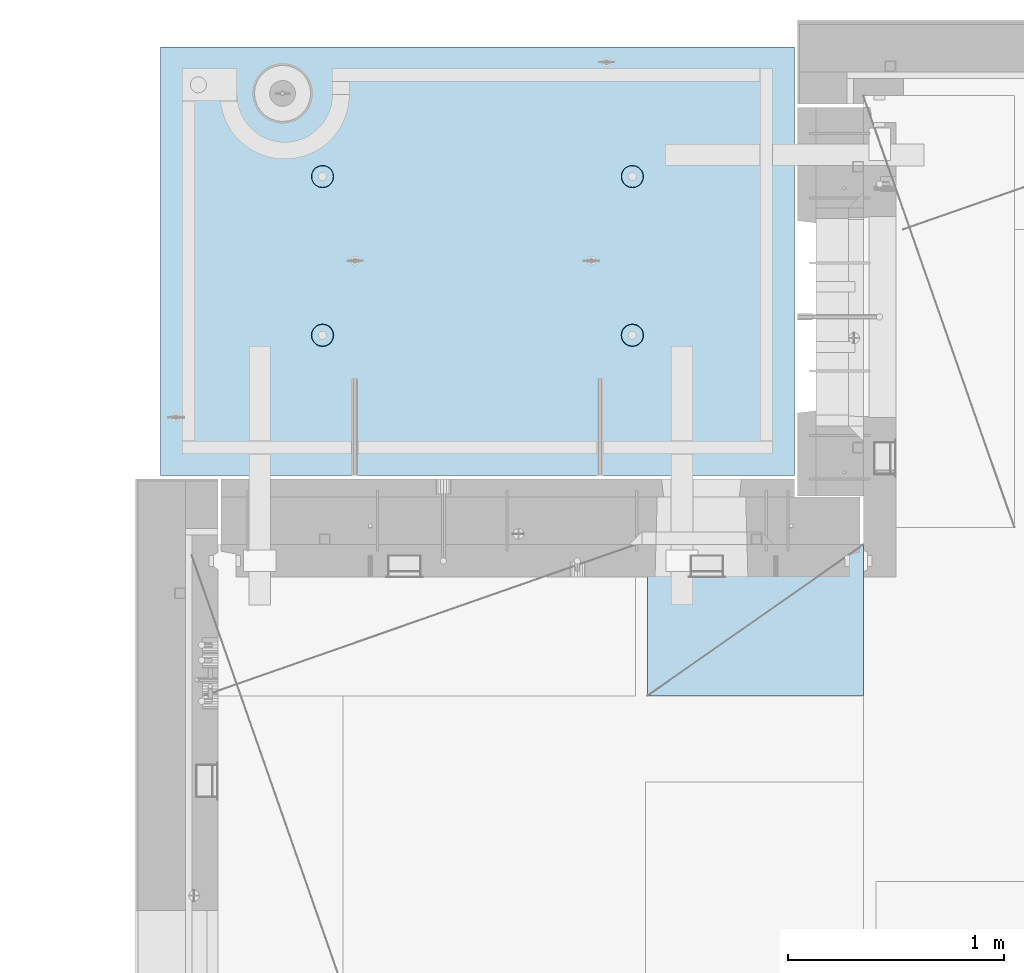
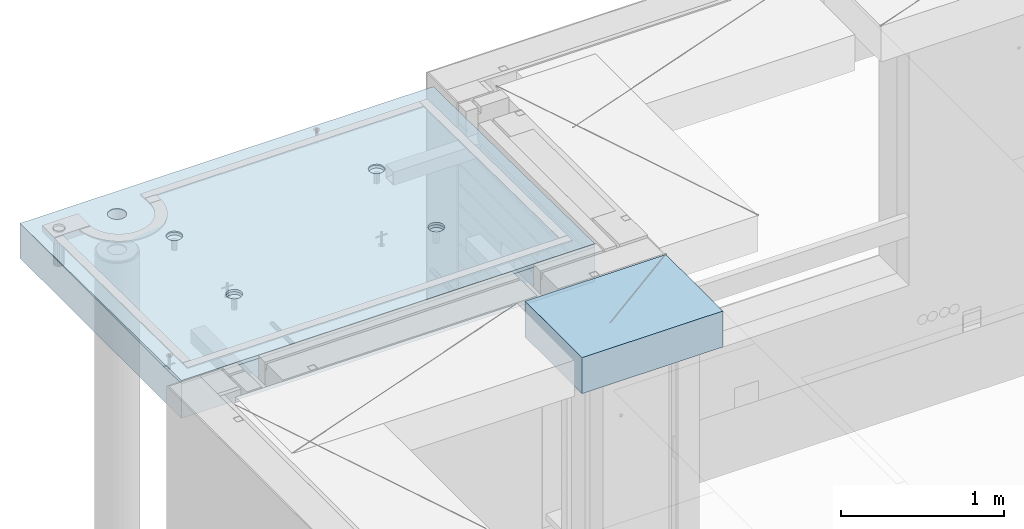
# One storey, part 206 of 350: 2 slabs, 1 plate, 2 elements without a shape of their own.
"""IFC2X3 building model written with IfcOpenShell, lengths in millimetres."""

import ifcopenshell
import ifcopenshell.guid

model = None  # the IFC model being written
_history = None  # IfcOwnerHistory: only IFC2X3 demands one
_inside = {}  # id of a spatial element -> (the spatial element, [elements in it])
_under = {}  # id of a project, library or spatial element -> (it, [spatial elements below it])
_declared = {}  # id of a project -> (the project, [libraries it declares])
_typed = {}  # id of a type object -> (the type object, [elements of that type])
_made_of = {}  # id of a material, layer set ... -> (it, [elements and type objects made of it])


def new_model(schema):
    """Start an empty IFC model of exactly this schema.

    Asked for "IFC4X3", IfcOpenShell would pick the latest addendum, in which some entities
    have other attributes; the version numbers below select the first issue.
    IFC2X3 requires an IfcOwnerHistory on every rooted entity: one is made here for all.
    """
    global model, _history
    if schema == "IFC4X3":
        model = ifcopenshell.file(schema_version=(4, 3, 0, 0))
    else:
        model = ifcopenshell.file(schema=schema)
    _inside.clear()
    _under.clear()
    _declared.clear()
    _typed.clear()
    _made_of.clear()
    _history = None
    if model.schema == "IFC2X3":
        org = make("IfcOrganization", Name="unknown")
        user = make(
            "IfcPersonAndOrganization",
            ThePerson=make("IfcPerson", FamilyName="unknown"),
            TheOrganization=org,
        )
        app = make(
            "IfcApplication",
            ApplicationDeveloper=org,
            Version="unknown",
            ApplicationFullName="unknown",
            ApplicationIdentifier="unknown",
        )
        _history = make(
            "IfcOwnerHistory",
            OwningUser=user,
            OwningApplication=app,
            ChangeAction="ADDED",
            CreationDate=0,
        )
    return model


def make(cls, **values):
    """One entity of the class cls with the attributes given. An attribute that is None is left unset."""
    return model.create_entity(
        cls, **{name: value for name, value in values.items() if value is not None}
    )


def rooted(cls, **values):
    """An entity with a GlobalId (a new one), such as an element, a storey or a relation."""
    return make(cls, GlobalId=ifcopenshell.guid.new(), OwnerHistory=_history, **values)


def si_unit(unit_type, name, prefix=None):
    """IfcSIUnit, for example si_unit("LENGTHUNIT", "METRE", prefix="MILLI")."""
    return make("IfcSIUnit", UnitType=unit_type, Prefix=prefix, Name=name)


def assignment(units):
    """IfcUnitAssignment: the units of a project."""
    return None if units is None else make("IfcUnitAssignment", Units=units)


def point(xyz):
    """IfcCartesianPoint."""
    return None if xyz is None else make("IfcCartesianPoint", Coordinates=xyz)


def direction(xyz):
    """IfcDirection."""
    return None if xyz is None else make("IfcDirection", DirectionRatios=xyz)


def frame(location, z_axis=None, x_axis=None):
    """IfcAxis2Placement3D, a coordinate frame: its origin and axes. An axis left out is left unset."""
    return make(
        "IfcAxis2Placement3D",
        Location=point(location),
        Axis=direction(z_axis),
        RefDirection=direction(x_axis),
    )


def origin_with_axes():
    """The frame at (0, 0, 0) with the z axis (0, 0, 1) and the x axis (1, 0, 0) written out."""
    return frame((0.0, 0.0, 0.0), z_axis=(0.0, 0.0, 1.0), x_axis=(1.0, 0.0, 0.0))


def place(relative_to, where):
    """IfcLocalPlacement: puts the frame where relative to a parent placement (None: the world)."""
    return make(
        "IfcLocalPlacement", PlacementRelTo=relative_to, RelativePlacement=where
    )


def context(
    kind, dimensions, precision=None, world=None, true_north=None, identifier=None
):
    """IfcGeometricRepresentationContext, for example the 3D "Model" context."""
    return make(
        "IfcGeometricRepresentationContext",
        ContextIdentifier=identifier,
        ContextType=kind,
        CoordinateSpaceDimension=dimensions,
        Precision=precision,
        WorldCoordinateSystem=world,
        TrueNorth=true_north,
    )


def subcontext(parent, identifier, kind, view, scale=None):
    """IfcGeometricRepresentationSubContext, for example "Body" below "Model"."""
    return make(
        "IfcGeometricRepresentationSubContext",
        ContextIdentifier=identifier,
        ContextType=kind,
        ParentContext=parent,
        TargetScale=scale,
        TargetView=view,
    )


def project(units=None, contexts=None):
    """IfcProject with its units and contexts."""
    return rooted(
        "IfcProject",
        Name="project",
        RepresentationContexts=contexts,
        UnitsInContext=assignment(units),
    )


def spatial(cls, under=None, at=None, **own):
    """A site, building, storey or space (cls), placed at a placement, below another one or the project."""
    s = rooted(cls, ObjectPlacement=at, **own)
    if under is not None:
        _under.setdefault(under.id(), (under, []))[1].append(s)
    return s


def faces_of(points, faces, orient=None, outer=None):
    """IfcFace entities. A face is a list of loops; a loop is a list of indices into points, from 0.

    orient and outer hold one flag for each loop. By default every Orientation is true, the
    first loop of a face is its IfcFaceOuterBound and the others are IfcFaceBound.
    """
    made = []
    for i, loops in enumerate(faces):
        bounds = []
        for j, loop in enumerate(loops):
            is_outer = j == 0 if outer is None else outer[i][j]
            bounds.append(
                make(
                    "IfcFaceOuterBound" if is_outer else "IfcFaceBound",
                    Bound=make("IfcPolyLoop", Polygon=[points[k] for k in loop]),
                    Orientation=True if orient is None else orient[i][j],
                )
            )
        made.append(make("IfcFace", Bounds=bounds))
    return made


def faceted_brep(points, faces, orient=None, outer=None, voids=None):
    """IfcFacetedBrep: a solid bounded by flat faces; with voids (closed shells), ...WithVoids."""
    shared = [point(p) for p in points]
    hull = make("IfcClosedShell", CfsFaces=faces_of(shared, faces, orient, outer))
    if voids is None:
        return make("IfcFacetedBrep", Outer=hull)
    return make(
        "IfcFacetedBrepWithVoids",
        Outer=hull,
        Voids=[
            make(cls, CfsFaces=faces_of(shared, fs, o, b)) for cls, fs, o, b in voids
        ],
    )


def shape(context_of_items, identifier, shape_type, items):
    """IfcShapeRepresentation: the items that make up one representation, for example the "Body"."""
    return make(
        "IfcShapeRepresentation",
        ContextOfItems=context_of_items,
        RepresentationIdentifier=identifier,
        RepresentationType=shape_type,
        Items=items,
    )


def material(Name=None, Category=None):
    """IfcMaterial."""
    return make("IfcMaterial", Name=Name, Category=Category)


def made_of(thing, what):
    """Note that an element or type object is made of a material, layer set ...; save() writes the relation."""
    if what is not None:
        _made_of.setdefault(what.id(), (what, []))[1].append(thing)
    return thing


def type_object(cls, material=None, **own):
    """A type object (cls), such as IfcWallType, which elements share."""
    return made_of(rooted(cls, **own), material)


def element(
    cls,
    number,
    at=None,
    inside=None,
    cuts=None,
    type_object=None,
    material=None,
    context=None,
    identifier="Body",
    shape_type=None,
    held_by="IfcProductDefinitionShape",
    body=None,
    shapes=None,
    **own,
):
    """One element of the class cls, such as IfcWall. Its Tag is "e" and its number.

    at: its placement. inside: the storey or other place that contains it. cuts: it is an
    opening in that element (IfcRelVoidsElement). A single representation is given by context,
    identifier, shape_type and body (its items); several are given by shapes. held_by: the class
    of the entity that holds the representations. save() writes the other relations.
    """
    e = rooted(cls, Tag="e%d" % number, ObjectPlacement=at, **own)
    if body is not None:
        shapes = [shape(context, identifier, shape_type, body)]
    if shapes is not None:
        e.Representation = make(held_by, Representations=shapes)
    if inside is not None:
        _inside.setdefault(inside.id(), (inside, []))[1].append(e)
    if cuts is not None:
        rooted(
            "IfcRelVoidsElement", RelatingBuildingElement=cuts, RelatedOpeningElement=e
        )
    if type_object is not None:
        _typed.setdefault(type_object.id(), (type_object, []))[1].append(e)
    return made_of(e, material)


def aggregate(whole, parts):
    """IfcRelAggregates: a whole, such as a stair, and the parts it consists of."""
    return rooted("IfcRelAggregates", RelatingObject=whole, RelatedObjects=parts)


def save(model, path):
    """Write the relations noted so far, then the file.

    IfcRelAggregates (storeys below a building ...), IfcRelContainedInSpatialStructure (elements
    in a storey), IfcRelDefinesByType, IfcRelAssociatesMaterial and IfcRelDeclares: one each for
    every whole, place, type object, material and project.
    """
    for whole, parts in _under.values():
        aggregate(whole, parts)
    for where, things in _inside.values():
        rooted(
            "IfcRelContainedInSpatialStructure",
            RelatedElements=things,
            RelatingStructure=where,
        )
    for kind, things in _typed.values():
        rooted("IfcRelDefinesByType", RelatedObjects=things, RelatingType=kind)
    for what, things in _made_of.values():
        rooted("IfcRelAssociatesMaterial", RelatedObjects=things, RelatingMaterial=what)
    for by, libraries in _declared.values():
        rooted("IfcRelDeclares", RelatingContext=by, RelatedDefinitions=libraries)
    model.write(path)


model = new_model("IFC2X3")

# Units and contexts
model_context = context("Model", 3, precision=1e-05, world=origin_with_axes())
body_context = subcontext(model_context, "Body", "Model", "MODEL_VIEW")
ifc_project = project(units=[si_unit("LENGTHUNIT", "METRE", prefix="MILLI"), si_unit("AREAUNIT", "SQUARE_METRE"), si_unit("VOLUMEUNIT", "CUBIC_METRE"), si_unit("MASSUNIT", "GRAM", prefix="KILO"), si_unit("TIMEUNIT", "SECOND"), si_unit("PLANEANGLEUNIT", "RADIAN"), si_unit("SOLIDANGLEUNIT", "STERADIAN"), si_unit("THERMODYNAMICTEMPERATUREUNIT", "DEGREE_CELSIUS"), si_unit("LUMINOUSINTENSITYUNIT", "LUMEN")], contexts=[model_context])

# Site, building, storey
site_placement = place(None, origin_with_axes())
site = spatial("IfcSite", under=ifc_project, at=site_placement, CompositionType="ELEMENT")
building_placement = place(site_placement, origin_with_axes())
building = spatial("IfcBuilding", under=site, at=building_placement, CompositionType="ELEMENT")
storey_placement = place(building_placement, origin_with_axes())
storey = spatial("IfcBuildingStorey", under=building, at=storey_placement, Name="2", CompositionType="ELEMENT", Elevation=0.0)

# Assembly, slabs
assembly_1_placement = place(storey_placement, origin_with_axes())
assembly_1 = element("IfcElementAssembly", 1, at=assembly_1_placement, inside=storey, AssemblyPlace="NOTDEFINED", PredefinedType="REINFORCEMENT_UNIT")
ifc_material_1 = material(Name="CONCRETE/C35/45")
slab_type_1 = type_object("IfcSlabType", PredefinedType="NOTDEFINED")
slab_1_placement = place(assembly_1_placement, frame((7734.99985681325, 20899.9965573523, 87717.5), z_axis=(0.0, 1.0, 0.0), x_axis=(1.0, 0.0, 0.0)))
slab_1 = element("IfcSlab", 2, at=slab_1_placement, type_object=slab_type_1, material=ifc_material_1, PredefinedType="FLOOR", context=body_context, shape_type="Brep", body=[
    faceted_brep([(209.64691778923, 8.87688398158934, 1795.66138892724), (209.64691778923, 12.5000000975269, 1795.66138892724), (201.519156607756, 12.5000000956934, 1783.49470026561), (201.519156607756, 8.73204270274437, 1783.49470026561), (189.354094229504, 12.5000000940054, 1775.36450517907), (189.354094229504, 8.63525483493868, 1775.36450517907), (175.003751124998, 12.5000000927103, 1772.50855216914), (175.003751124998, 8.60125545370101, 1772.50855216914), (160.652836945715, 12.5000000920118, 1775.36163419229), (160.652836945715, 8.63522065659345, 1775.36163419229), (148.48614828409, 12.5000000919972, 1783.48939537376), (148.48614828409, 8.73197954936768, 1783.48939537376), (140.355953197546, 12.5000000926811, 1795.65445775201), (140.355953197546, 8.87680146773346, 1795.65445775201), (137.500000187611, 12.5000000939617, 1810.00480085652), (137.500000187611, 9.04763858744991, 1810.00480085652), (140.353082210766, 12.5000000956497, 1824.35571503581), (140.353082210766, 9.21848250564653, 1824.35571503581), (148.48084339224, 12.5000000974687, 1836.52240369743), (148.48084339224, 9.36332378449151, 1836.52240369743), (160.645905770492, 12.5000000991568, 1844.65259878397), (160.645905770492, 9.4601116522972, 1844.65259878397), (174.996248874998, 12.5000001004519, 1847.50855179391), (174.996248874998, 9.49411103353486, 1847.50855179391), (189.347163054282, 12.5000001011649, 1844.65546977075), (189.347163054282, 9.46014583064243, 1844.65546977075), (201.513851715907, 12.5000001011795, 1836.52770858928), (201.513851715907, 9.3633869378682, 1836.52770858928), (209.64404680245, 12.500000100481, 1824.36264621103), (209.64404680245, 9.21856501948787, 1824.36264621103), (212.499999812386, 12.5000000992004, 1810.01230310652), (212.499999812386, 9.04772789980052, 1810.01230310652), (0.0, 12.5, 1985.00366210938), (7.41420080885291e-08, 12.4999999999927, 0.0), (-7.41420080885291e-08, -12.5, -3.63797880709171e-12), (0.0, 11.1309547276614, 1985.00366210938), (2935.0, 12.5000004097383, 1985.00366209901), (2935.0, 11.1309547276614, 1985.00366210938), (2935.0, 12.5, 0.0), (2935.0, -12.5, 0.0), (2234.65136896188, -4.56985165992228, 666.133623356985), (2233.6850359994, 12.5000001221924, 665.819642744358), (2236.1904762364, 12.5000001207372, 650.000915653603), (2237.21797072983, -4.76190736876742, 650.000915653603), (2227.22763735012, -4.39666783543362, 680.68109000706), (2226.41396523543, 12.5000001231529, 680.089922611885), (2215.67536748502, -4.25927704213245, 692.221936790684), (2215.08900701139, 12.5000001235312, 691.414880835895), (2201.12537297611, -4.17108941465267, 699.629710429519), (2200.81872714385, 12.5000001232838, 698.685951599829), (2185.00000005312, -4.14070613867079, 702.181910066618), (2185.00000005312, 12.5000001224398, 701.19139183679), (2168.87462713012, -4.17108941465267, 699.629710429519), (2169.18127296234, 12.5000001210865, 698.685951599953), (2154.32463262121, -4.25927704213245, 692.221936790684), (2154.9109930947, 12.5000001193257, 691.414880836099), (2142.77236275611, -4.39666783543362, 680.68109000706), (2143.58603487053, 12.5000001173757, 680.089922612086), (2135.34863114435, -4.56985165992228, 666.133623356985), (2136.31496410644, 12.5000001153967, 665.819642744485), (2132.7820293764, -4.76190736876742, 650.000915653603), (2133.8095238694, 12.5000001135923, 650.000915653603), (2135.3268816397, -4.95404720651277, 633.861141107776), (2136.31496410626, 12.5000001121371, 634.182188562663), (2142.73717131393, -5.12745128343522, 619.29517322078), (2143.58603487023, 12.5000001111621, 619.911908694903), (2154.28944117357, -5.26511432380357, 607.731457644233), (2154.9109930944, 12.5000001107837, 608.586950470697), (2168.85287761663, -5.35352220384812, 600.305182758089), (2169.18127296215, 12.5000001110311, 601.315879706683), (2185.00000005312, -5.38398960883205, 597.745916272124), (2185.00000005312, 12.5000001118751, 598.810439469788), (2201.1471224896, -5.35352220384812, 600.305182758089), (2200.81872714404, 12.500000113243, 601.31587970681), (2215.71055893266, -5.26511432380357, 607.731457644233), (2215.08900701168, 12.5000001149892, 608.586950470901), (2227.2628287923, -5.12745128343522, 619.29517322078), (2226.41396523573, 12.5000001169392, 619.911908695103), (2234.67311846653, -4.95404720651277, 633.861141107776), (2233.68503599959, 12.5000001189328, 634.182188562787), (799.651368961879, -4.56985165992228, 666.133623356985), (798.685036005074, 12.5000000220316, 665.819642746203), (801.190476242367, 12.5000000205619, 650.000915653603), (802.217970729829, -4.76190736876742, 650.000915653603), (792.227637350119, -4.39666783543362, 680.68109000706), (791.41396524025, 12.500000022992, 680.089922615389), (780.675367485019, -4.25927704213245, 692.221936790684), (780.089007014889, 12.5000000233704, 691.414880840719), (766.125372976112, -4.17108941465267, 699.629710429519), (765.818727145695, 12.500000023123, 698.685951605497), (750.000000053116, -4.14070613867079, 702.181910066618), (750.000000053116, 12.500000022279, 701.191391842753), (733.874627130121, -4.17108941465267, 699.629710429519), (734.181272960497, 12.5000000209257, 698.685951605625), (719.324632621214, -4.25927704213245, 692.221936790684), (719.910993091196, 12.5000000191649, 691.414880840923), (707.772362756114, -4.39666783543362, 680.68109000706), (708.586034865702, 12.5000000172149, 680.089922615593), (700.348631144354, -4.56985165992228, 666.133623356985), (701.314964100775, 12.5000000152359, 665.819642746326), (697.782029376403, -4.76190736876742, 650.000915653603), (698.80952386344, 12.5000000134314, 650.000915653603), (700.326881639705, -4.95404720651277, 633.861141107776), (701.314964100589, 12.5000000119617, 634.182188560822), (707.737171313933, -5.12745128343522, 619.29517322078), (708.586034865404, 12.5000000110012, 619.911908691396), (719.289441173572, -5.26511432380357, 607.731457644233), (719.910993090896, 12.5000000106229, 608.586950465873), (733.852877616633, -5.35352220384812, 600.305182758089), (734.181272960313, 12.5000000108703, 601.315879701015), (750.000000053116, -5.38398960883205, 597.745916272124), (750.000000053116, 12.5000000117143, 598.810439463825), (766.1471224896, -5.35352220384812, 600.305182758089), (765.818727145879, 12.5000000130822, 601.315879701138), (780.71055893266, -5.26511432380357, 607.731457644233), (780.089007015189, 12.5000000148284, 608.586950466077), (792.2628287923, -5.12745128343522, 619.29517322078), (791.413965240548, 12.5000000167784, 619.9119086916), (799.673118466528, -4.95404720651277, 633.861141107776), (798.685036005258, 12.500000018772, 634.182188560946), (799.156135017123, 4.17823925742414, 1400.9745431382), (798.685035917459, 12.5000000978907, 1400.82147376184), (801.190476154532, 12.5000000964355, 1385.00274667064), (801.697136924844, 3.98809915517631, 1385.00274667064), (791.806449365287, 4.3496957076859, 1415.37691010137), (791.413965153277, 12.5000000988512, 1415.09175362977), (780.369404424282, 4.48571613449894, 1426.80264589727), (780.089006928914, 12.5000000992295, 1426.4167118541), (765.96453481571, 4.57302415884624, 1434.13653274457), (765.818727060978, 12.5000000989821, 1433.68778261824), (749.999999969796, 4.6031043852272, 1436.66327617152), (749.999999969796, 12.5000000981381, 1436.19322285528), (734.035465123881, 4.57302415884624, 1434.13653274457), (734.181272878572, 12.5000000967848, 1433.68778261837), (719.630595515309, 4.48571613449894, 1426.80264589727), (719.91099301053, 12.5000000950386, 1426.41671185431), (708.193550574304, 4.3496957076859, 1415.37691010137), (708.586034786036, 12.5000000930741, 1415.09175362997), (700.843864922468, 4.17823925742414, 1400.9745431382), (701.314964021747, 12.500000091095, 1400.82147376197), (698.302863014747, 3.98809915517631, 1385.00274667064), (698.809523784634, 12.500000089276, 1385.00274667064), (700.822332352242, 3.79787576314993, 1369.0239538469), (701.314964021563, 12.5000000878208, 1369.18401957925), (708.15871013944, 3.62620125728427, 1354.60327018229), (708.586034785736, 12.5000000868604, 1354.91373971109), (719.595755075041, 3.48991129887872, 1343.15489369192), (719.91099301023, 12.500000086482, 1343.58878148656), (734.013932544907, 3.40238521881111, 1335.80269013289), (734.181272878388, 12.5000000867294, 1336.31771072235), (749.999999969796, 3.37222170254972, 1333.26895034341), (749.999999969796, 12.5000000875589, 1333.81227048538), (765.986067394684, 3.40238521881111, 1335.80269013289), (765.818727061163, 12.5000000889413, 1336.31771072247), (780.40424486455, 3.48991129887872, 1343.15489369192), (780.089006929215, 12.500000090673, 1343.58878148677), (791.841289800152, 3.62620125728427, 1354.60327018229), (791.413965153577, 12.5000000926375, 1354.91373971129), (799.17766758735, 3.79787576314993, 1369.0239538469), (798.685035917644, 12.5000000946166, 1369.18401957938), (2234.15613501712, 4.17823925742414, 1400.9745431382), (2233.68503591179, 12.5000001980516, 1400.82147376), (2236.19047614857, 12.5000001965964, 1385.00274667064), (2236.69713692484, 3.98809915517631, 1385.00274667064), (2226.80644936529, 4.3496957076859, 1415.37691010137), (2226.41396514845, 12.5000001990265, 1415.09175362627), (2215.36940442428, 4.48571613449894, 1426.80264589727), (2215.08900692541, 12.5000001993903, 1426.41671184928), (2200.96453481571, 4.57302415884624, 1434.13653274457), (2200.81872705914, 12.5000001991575, 1433.68778261257), (2184.9999999698, 4.6031043852272, 1436.66327617152), (2184.9999999698, 12.5000001982989, 1436.19322284931), (2169.03546512388, 4.57302415884624, 1434.13653274457), (2169.18127288041, 12.5000001969456, 1433.6877826127), (2154.63059551531, 4.48571613449894, 1426.80264589727), (2154.91099301403, 12.5000001951994, 1426.41671184948), (2143.1935505743, 4.3496957076859, 1415.37691010137), (2143.58603479086, 12.5000001932349, 1415.09175362647), (2135.84386492247, 4.17823925742414, 1400.9745431382), (2136.31496402742, 12.5000001912558, 1400.82147376013), (2133.30286301475, 3.98809915517631, 1385.00274667064), (2133.8095237906, 12.5000001894368, 1385.00274667064), (2135.82233235224, 3.79787576314993, 1369.0239538469), (2136.31496402723, 12.5000001879816, 1369.18401958109), (2143.15871013944, 3.62620125728427, 1354.60327018229), (2143.58603479056, 12.5000001870212, 1354.91373971459), (2154.59575507504, 3.48991129887872, 1343.15489369192), (2154.91099301373, 12.5000001866429, 1343.58878149139), (2169.01393254491, 3.40238521881111, 1335.80269013289), (2169.18127288023, 12.5000001868902, 1336.31771072802), (2184.9999999698, 3.37222170254972, 1333.26895034341), (2184.9999999698, 12.5000001877343, 1333.81227049134), (2200.98606739468, 3.40238521881111, 1335.80269013289), (2200.81872705932, 12.5000001891021, 1336.31771072814), (2215.40424486455, 3.48991129887872, 1343.15489369192), (2215.08900692571, 12.5000001908338, 1343.58878149159), (2226.84128980015, 3.62620125728427, 1354.60327018229), (2226.41396514875, 12.5000001927983, 1354.9137397148), (2234.17766758735, 3.79787576314993, 1369.0239538469), (2233.68503591197, 12.5000001947919, 1369.18401958122), (613.539958053605, 8.15176414522284, 1734.75121634823), (600.266053528658, 7.99374174815603, 1721.47731182328), (583.539958053605, 7.89228512388945, 1712.95494050807), (564.998938391109, 7.85732555369032, 1710.01833148578), (546.457918728613, 7.89228512388945, 1712.95494050807), (529.73182325356, 7.99374174815603, 1721.47731182328), (516.457918728613, 8.15176414522284, 1734.75121634823), (507.935547413399, 8.35088398186781, 1751.47731182328), (504.998938391109, 8.57161002114299, 1770.01833148578), (507.935547413399, 8.79233606038906, 1788.55935114828), (516.457918728613, 8.99145589703403, 1805.28544662333), (529.73182325356, 9.1494782941154, 1818.55935114828), (546.457918728613, 9.25093491838197, 1827.08172246349), (564.998938391109, 9.28589448856656, 1830.01833148578), (583.539958053605, 9.25093491838197, 1827.08172246349), (600.266053528658, 9.1494782941154, 1818.55935114828), (613.539958053605, 8.99145589703403, 1805.28544662333), (622.062329368819, 8.79233606038906, 1788.55935114828), (624.998938391109, 8.57161002114299, 1770.01833148578), (622.062329368819, 8.35088398186781, 1751.47731182328), (613.539958053605, 12.5, 1805.28544662333), (622.062329368819, 12.5, 1788.55935114828), (600.266053528658, 12.5, 1818.55935114828), (583.539958053605, 12.5, 1827.08172246349), (564.998938391109, 12.5, 1830.01833148578), (546.457918728613, 12.5, 1827.08172246349), (529.73182325356, 12.5, 1818.55935114828), (516.457918728613, 12.5, 1805.28544662333), (507.935547413399, 12.5, 1788.55935114828), (504.998938391109, 12.5, 1770.01833148578), (507.935547413399, 12.5, 1751.47731182328), (516.457918728613, 12.5, 1734.75121634823), (529.73182325356, 12.5, 1721.47731182328), (546.457918728613, 12.5, 1712.95494050807), (564.998938391109, 12.5, 1710.01833148578), (583.539958053605, 12.5, 1712.95494050807), (600.266053528658, 12.5, 1721.47731182328), (613.539958053605, 12.5, 1734.75121634823), (622.062329368819, 12.5, 1751.47731182328), (624.998938391109, 12.5, 1770.01833148578)], [[[0, 1, 2, 3]], [[3, 2, 4, 5]], [[5, 4, 6, 7]], [[7, 6, 8, 9]], [[9, 8, 10, 11]], [[11, 10, 12, 13]], [[13, 12, 14, 15]], [[15, 14, 16, 17]], [[17, 16, 18, 19]], [[19, 18, 20, 21]], [[21, 20, 22, 23]], [[23, 22, 24, 25]], [[25, 24, 26, 27]], [[27, 26, 28, 29]], [[29, 28, 30, 31]], [[31, 30, 1, 0]], [[32, 33, 34, 35]], [[36, 32, 35, 37]], [[38, 36, 37, 39]], [[33, 38, 39, 34]], [[40, 41, 42, 43]], [[44, 45, 41, 40]], [[46, 47, 45, 44]], [[48, 49, 47, 46]], [[50, 51, 49, 48]], [[52, 53, 51, 50]], [[53, 52, 54, 55]], [[55, 54, 56, 57]], [[57, 56, 58, 59]], [[59, 58, 60, 61]], [[61, 60, 62, 63]], [[63, 62, 64, 65]], [[65, 64, 66, 67]], [[67, 66, 68, 69]], [[69, 68, 70, 71]], [[72, 73, 71, 70]], [[74, 75, 73, 72]], [[76, 77, 75, 74]], [[78, 79, 77, 76]], [[43, 42, 79, 78]], [[80, 81, 82, 83]], [[84, 85, 81, 80]], [[86, 87, 85, 84]], [[88, 89, 87, 86]], [[90, 91, 89, 88]], [[92, 93, 91, 90]], [[93, 92, 94, 95]], [[95, 94, 96, 97]], [[97, 96, 98, 99]], [[99, 98, 100, 101]], [[101, 100, 102, 103]], [[103, 102, 104, 105]], [[105, 104, 106, 107]], [[107, 106, 108, 109]], [[109, 108, 110, 111]], [[112, 113, 111, 110]], [[114, 115, 113, 112]], [[116, 117, 115, 114]], [[118, 119, 117, 116]], [[83, 82, 119, 118]], [[120, 121, 122, 123]], [[124, 125, 121, 120]], [[126, 127, 125, 124]], [[128, 129, 127, 126]], [[130, 131, 129, 128]], [[132, 133, 131, 130]], [[134, 135, 133, 132]], [[135, 134, 136, 137]], [[137, 136, 138, 139]], [[139, 138, 140, 141]], [[141, 140, 142, 143]], [[143, 142, 144, 145]], [[145, 144, 146, 147]], [[147, 146, 148, 149]], [[149, 148, 150, 151]], [[151, 150, 152, 153]], [[154, 155, 153, 152]], [[156, 157, 155, 154]], [[158, 159, 157, 156]], [[123, 122, 159, 158]], [[160, 161, 162, 163]], [[164, 165, 161, 160]], [[166, 167, 165, 164]], [[168, 169, 167, 166]], [[170, 171, 169, 168]], [[172, 173, 171, 170]], [[174, 175, 173, 172]], [[175, 174, 176, 177]], [[177, 176, 178, 179]], [[179, 178, 180, 181]], [[181, 180, 182, 183]], [[183, 182, 184, 185]], [[185, 184, 186, 187]], [[187, 186, 188, 189]], [[189, 188, 190, 191]], [[191, 190, 192, 193]], [[194, 195, 193, 192]], [[196, 197, 195, 194]], [[198, 199, 197, 196]], [[163, 162, 199, 198]], [[37, 35, 34, 39], [3, 5, 7, 9, 11, 13, 15, 17, 19, 21, 23, 25, 27, 29, 31, 0], [200, 201, 202, 203, 204, 205, 206, 207, 208, 209, 210, 211, 212, 213, 214, 215, 216, 217, 218, 219], [196, 194, 192, 190, 188, 186, 184, 182, 180, 178, 176, 174, 172, 170, 168, 166, 164, 160, 163, 198], [156, 154, 152, 150, 148, 146, 144, 142, 140, 138, 136, 134, 132, 130, 128, 126, 124, 120, 123, 158], [116, 114, 112, 110, 108, 106, 104, 102, 100, 98, 96, 94, 92, 90, 88, 86, 84, 80, 83, 118], [76, 74, 72, 70, 68, 66, 64, 62, 60, 58, 56, 54, 52, 50, 48, 46, 44, 40, 43, 78]], [[216, 220, 221, 217]], [[215, 222, 220, 216]], [[214, 223, 222, 215]], [[213, 224, 223, 214]], [[212, 225, 224, 213]], [[211, 226, 225, 212]], [[210, 227, 226, 211]], [[209, 228, 227, 210]], [[208, 229, 228, 209]], [[207, 230, 229, 208]], [[206, 231, 230, 207]], [[205, 232, 231, 206]], [[204, 233, 232, 205]], [[203, 234, 233, 204]], [[202, 235, 234, 203]], [[201, 236, 235, 202]], [[200, 237, 236, 201]], [[219, 238, 237, 200]], [[218, 239, 238, 219]], [[217, 221, 239, 218]], [[38, 33, 32, 36], [26, 24, 22, 20, 18, 16, 14, 12, 10, 8, 6, 4, 2, 1, 30, 28], [220, 222, 223, 224, 225, 226, 227, 228, 229, 230, 231, 232, 233, 234, 235, 236, 237, 238, 239, 221], [165, 167, 169, 171, 173, 175, 177, 179, 181, 183, 185, 187, 189, 191, 193, 195, 197, 199, 162, 161], [125, 127, 129, 131, 133, 135, 137, 139, 141, 143, 145, 147, 149, 151, 153, 155, 157, 159, 122, 121], [85, 87, 89, 91, 93, 95, 97, 99, 101, 103, 105, 107, 109, 111, 113, 115, 117, 119, 82, 81], [45, 47, 49, 51, 53, 55, 57, 59, 61, 63, 65, 67, 69, 71, 73, 75, 77, 79, 42, 41]]]),
])
slab_type_2 = type_object("IfcSlabType", PredefinedType="NOTDEFINED")
slab_2_placement = place(assembly_1_placement, frame((7734.99985681325, 20899.9965573523, 87575.0), z_axis=(-2.2639999995273e-06, 0.999999999997437, 0.0), x_axis=(0.999999999997251, 2.34499999952812e-06, 0.0)))
slab_2 = element("IfcSlab", 3, at=slab_2_placement, type_object=slab_type_2, material=ifc_material_1, PredefinedType="FLOOR", context=body_context, shape_type="Brep", body=[
    faceted_brep([(2200.45398600256, -110.0, 1337.44476079497), (2214.39241555253, -110.0, 1344.54670420538), (2225.45402859605, -110.0, 1355.60826537005), (2232.55603737762, -110.0, 1369.54666161175), (2235.0032477951, -110.0, 1384.99750559184), (2232.5561098421, -110.0, 1400.44836104917), (2225.45416643169, -110.0, 1414.38679059914), (2214.39260526702, -110.0, 1425.44840364265), (2200.45420902531, -110.0, 1432.55041242422), (2185.00336504523, -110.0, 1434.9976228417), (2169.55250958791, -110.0, 1432.55048488871), (2155.61408003793, -110.0, 1425.44854147829), (2144.55246699442, -110.0, 1414.38698031362), (2137.45045821285, -110.0, 1400.44858407192), (2135.00324779537, -110.0, 1384.99774009184), (2137.45038574836, -110.0, 1369.54688463451), (2144.55232915878, -110.0, 1355.60845508454), (2155.61389032345, -110.0, 1344.54684204102), (2169.55228656515, -110.0, 1337.44483325945), (2185.00313054523, -110.0, 1334.99762284198), (2226.41728354208, -130.0, 1415.08653268859), (2233.68832084322, -130.0, 1400.81623576839), (2215.09235187349, -130.0, 1426.41151747124), (2200.8220890546, -130.0, 1433.68262169999), (2185.0033678369, -130.0, 1436.18809903217), (2169.18463486868, -130.0, 1433.68269588982), (2154.91433794847, -130.0, 1426.41165858869), (2143.58935316583, -130.0, 1415.08672692009), (2136.31824893708, -130.0, 1400.81646410121), (2133.8127716049, -130.0, 1384.9977428835), (2136.31817474725, -130.0, 1369.17900991529), (2143.58921204838, -130.0, 1354.90871299508), (2154.91414371698, -130.0, 1343.58372821243), (2169.18440653586, -130.0, 1336.31262398369), (2185.00312775357, -130.0, 1333.8071466515), (2200.82186072178, -130.0, 1336.31254979386), (2215.09215764199, -130.0, 1343.58358709499), (2226.41714242464, -130.0, 1354.90851876358), (2233.68824665339, -130.0, 1369.17878158247), (2236.19372398557, -130.0, 1384.99750280017), (765.453986006505, -110.0, 1337.44812586997), (779.392415556478, -110.0, 1344.55006928038), (790.454028599992, -110.0, 1355.61163044505), (797.556037381562, -110.0, 1369.55002668675), (800.003247799041, -110.0, 1385.00087066684), (797.556109846048, -110.0, 1400.45172612417), (790.454166435635, -110.0, 1414.39015567414), (779.392605270965, -110.0, 1425.45176871765), (765.45420902926, -110.0, 1432.55377749922), (750.003365049179, -110.0, 1435.0009879167), (734.552509591851, -110.0, 1432.55384996371), (720.614080041878, -110.0, 1425.4519065533), (709.552466998364, -110.0, 1414.39034538862), (702.450458216794, -110.0, 1400.45194914692), (700.003247799315, -110.0, 1385.00110516684), (702.450385752309, -110.0, 1369.5502497095), (709.552329162721, -110.0, 1355.61182015954), (720.613890327391, -110.0, 1344.55020711602), (734.552286569096, -110.0, 1337.44819833446), (750.003130549179, -110.0, 1335.00098791698), (798.688320847163, -130.0, 1400.81960084339), (801.193723989514, -130.0, 1385.00086787517), (791.417283546027, -130.0, 1415.0898977636), (780.092351877434, -130.0, 1426.41488254624), (765.822089058547, -130.0, 1433.68598677499), (750.003367840845, -130.0, 1436.19146410717), (734.184634872629, -130.0, 1433.68606096482), (719.914337952418, -130.0, 1426.41502366369), (708.589353169771, -130.0, 1415.09009199509), (701.318248941023, -130.0, 1400.81982917621), (698.812771608842, -130.0, 1385.00110795851), (701.318174751194, -130.0, 1369.18237499029), (708.589212052329, -130.0, 1354.91207807008), (719.914143720922, -130.0, 1343.58709328743), (734.184406539811, -130.0, 1336.31598905868), (750.003127757513, -130.0, 1333.8105117265), (765.821860725729, -130.0, 1336.31591486885), (780.092157645939, -130.0, 1343.58695216999), (791.417142428585, -130.0, 1354.91188383858), (798.688246657333, -130.0, 1369.18214665747), (2935.0, -130.0, 1.16051523946226e-09), (0.0, -130.0, -3.63797880709171e-12), (0.0, 130.0, -1.81898940354586e-12), (2935.0, 130.0, 1.16051523946226e-09), (2935.00146484375, -130.0, 1985.00366210938), (2935.00146484375, 130.0, 1985.00366210938), (0.00127768016045593, -130.0, 1985.00366210937), (0.00127768016045593, 130.0, 1985.00366210937), (613.544191446293, 130.0, 1805.28400786653), (600.270318048689, 130.0, 1818.55794351875), (583.544242558642, 130.0, 1827.08035405663), (565.003229782545, 130.0, 1830.0170065576), (546.462203233751, 130.0, 1827.08044101401), (529.736087773786, 130.0, 1818.55810892152), (516.462152121568, 130.0, 1805.28423552391), (507.939741583684, 130.0, 1788.55816003387), (505.00308908271, 130.0, 1770.01714725777), (507.939654626302, 130.0, 1751.47612070897), (516.461986718798, 130.0, 1734.75000524901), (529.735860116402, 130.0, 1721.47606959679), (546.461935606448, 130.0, 1712.95365905891), (565.002948382545, 130.0, 1710.01700655793), (583.543974931338, 130.0, 1712.95357210152), (600.270090391306, 130.0, 1721.47590419402), (613.544026043523, 130.0, 1734.74977759163), (622.066436581407, 130.0, 1751.47585308167), (625.003089082381, 130.0, 1770.01686585777), (622.066523538789, 130.0, 1788.55789240656), (622.066523538789, -130.0, 1788.55789240656), (625.003089082381, -130.0, 1770.01686585777), (613.544191446293, -130.0, 1805.28400786653), (600.270318048689, -130.0, 1818.55794351875), (583.544242558642, -130.0, 1827.08035405663), (565.003229782545, -130.0, 1830.0170065576), (546.462203233751, -130.0, 1827.08044101401), (529.736087773786, -130.0, 1818.55810892152), (516.462152121568, -130.0, 1805.28423552391), (507.939741583684, -130.0, 1788.55816003387), (505.00308908271, -130.0, 1770.01714725777), (507.939654626302, -130.0, 1751.47612070897), (516.461986718798, -130.0, 1734.75000524901), (529.735860116402, -130.0, 1721.47606959679), (546.461935606448, -130.0, 1712.95365905891), (565.002948382545, -130.0, 1710.01700655793), (583.543974931338, -130.0, 1712.95357210152), (600.270090391306, -130.0, 1721.47590419402), (613.544026043523, -130.0, 1734.74977759163), (622.066436581407, -130.0, 1751.47585308167), (765.452262510529, -110.0, 602.446294854952), (779.390692060502, -110.0, 609.548238265361), (790.452305104016, -110.0, 620.609799430033), (797.554313885586, -110.0, 634.548195671738), (800.001524303065, -110.0, 649.999039651819), (797.554386350072, -110.0, 665.449895109152), (790.452442939657, -110.0, 679.388324659118), (779.390881774987, -110.0, 690.449937702637), (765.452485533282, -110.0, 697.551946484204), (750.001641553203, -110.0, 699.999156901682), (734.550786095873, -110.0, 697.552018948689), (720.6123565459, -110.0, 690.45007553828), (709.550743502386, -110.0, 679.388514373604), (702.448734720818, -110.0, 665.450118131903), (700.001524303339, -110.0, 649.999274151818), (702.448662256333, -110.0, 634.548418694489), (709.550605666745, -110.0, 620.609989144519), (720.612166831415, -110.0, 609.548376101004), (734.55056307312, -110.0, 602.446367319437), (750.001407053202, -110.0, 599.999156901958), (798.686597351187, -130.0, 665.817769828369), (801.192000493538, -130.0, 649.999036860154), (791.415560050051, -130.0, 680.088066748576), (780.090628381458, -130.0, 691.413051531228), (765.820365562571, -130.0, 698.684155759973), (750.001644344869, -130.0, 701.189633092159), (734.182911376653, -130.0, 698.684229949802), (719.912614456442, -130.0, 691.41319264867), (708.587629673795, -130.0, 680.088260980072), (701.316525445047, -130.0, 665.817998161187), (698.811048112866, -130.0, 649.999276943487), (701.316451255216, -130.0, 634.180543975268), (708.587488556352, -130.0, 619.910247055061), (719.912420224944, -130.0, 608.585262272412), (734.182683043833, -130.0, 601.314158043664), (750.001404261535, -130.0, 598.808680711485), (765.820137229752, -130.0, 601.314083853835), (780.090434149961, -130.0, 608.585121154971), (791.415418932607, -130.0, 619.910052823565), (798.686523161356, -130.0, 634.18031564245), (2200.45226250658, -110.0, 602.442929779951), (2214.39069205656, -110.0, 609.544873190363), (2225.45230510007, -110.0, 620.606434355035), (2232.55431388164, -110.0, 634.544830596737), (2235.00152429912, -110.0, 649.995674576818), (2232.55438634613, -110.0, 665.446530034151), (2225.45244293571, -110.0, 679.38495958412), (2214.39088177104, -110.0, 690.446572627639), (2200.45248552934, -110.0, 697.548581409203), (2185.00164154926, -110.0, 699.995791826681), (2169.55078609193, -110.0, 697.548653873688), (2155.61235654195, -110.0, 690.446710463279), (2144.55074349844, -110.0, 679.385149298603), (2137.44873471687, -110.0, 665.446753056905), (2135.00152429939, -110.0, 649.995909076821), (2137.44866225239, -110.0, 634.545053619491), (2144.5506056628, -110.0, 620.606624069518), (2155.61216682747, -110.0, 609.545011026003), (2169.55056306918, -110.0, 602.443002244436), (2185.00140704926, -110.0, 599.995791826957), (2233.68659734724, -130.0, 665.814404753368), (2236.19200048959, -130.0, 649.995671785153), (2226.41556004611, -130.0, 680.084701673575), (2215.09062837751, -130.0, 691.409686456227), (2200.82036555863, -130.0, 698.680790684972), (2185.00164434092, -130.0, 701.186268017158), (2169.18291137271, -130.0, 698.680864874805), (2154.9126144525, -130.0, 691.409827573672), (2143.58762966985, -130.0, 680.084895905075), (2136.3165254411, -130.0, 665.814633086189), (2133.81104810892, -130.0, 649.995911868486), (2136.31645125127, -130.0, 634.177178900271), (2143.58748855241, -130.0, 619.906881980063), (2154.912420221, -130.0, 608.581897197415), (2169.18268303989, -130.0, 601.310792968667), (2185.00140425759, -130.0, 598.805315636484), (2200.82013722581, -130.0, 601.310718778834), (2215.09043414602, -130.0, 608.58175607997), (2226.41541892866, -130.0, 619.906687748564), (2233.68652315741, -130.0, 634.176950567449)], [[[0, 1, 2, 3, 4, 5, 6, 7, 8, 9, 10, 11, 12, 13, 14, 15, 16, 17, 18, 19]], [[20, 6, 5, 21]], [[22, 7, 6, 20]], [[23, 8, 7, 22]], [[24, 9, 8, 23]], [[25, 10, 9, 24]], [[26, 11, 10, 25]], [[27, 12, 11, 26]], [[28, 13, 12, 27]], [[29, 14, 13, 28]], [[30, 15, 14, 29]], [[31, 16, 15, 30]], [[32, 17, 16, 31]], [[33, 18, 17, 32]], [[34, 19, 18, 33]], [[35, 0, 19, 34]], [[36, 1, 0, 35]], [[37, 2, 1, 36]], [[38, 3, 2, 37]], [[39, 4, 3, 38]], [[21, 5, 4, 39]], [[40, 41, 42, 43, 44, 45, 46, 47, 48, 49, 50, 51, 52, 53, 54, 55, 56, 57, 58, 59]], [[60, 45, 44, 61]], [[62, 46, 45, 60]], [[63, 47, 46, 62]], [[64, 48, 47, 63]], [[65, 49, 48, 64]], [[66, 50, 49, 65]], [[67, 51, 50, 66]], [[68, 52, 51, 67]], [[69, 53, 52, 68]], [[70, 54, 53, 69]], [[71, 55, 54, 70]], [[72, 56, 55, 71]], [[73, 57, 56, 72]], [[74, 58, 57, 73]], [[75, 59, 58, 74]], [[76, 40, 59, 75]], [[77, 41, 40, 76]], [[78, 42, 41, 77]], [[79, 43, 42, 78]], [[61, 44, 43, 79]], [[80, 81, 82, 83]], [[84, 80, 83, 85]], [[86, 84, 85, 87]], [[81, 86, 87, 82]], [[85, 83, 82, 87], [88, 89, 90, 91, 92, 93, 94, 95, 96, 97, 98, 99, 100, 101, 102, 103, 104, 105, 106, 107]], [[108, 107, 106, 109]], [[110, 88, 107, 108]], [[111, 89, 88, 110]], [[112, 90, 89, 111]], [[113, 91, 90, 112]], [[114, 92, 91, 113]], [[115, 93, 92, 114]], [[116, 94, 93, 115]], [[117, 95, 94, 116]], [[118, 96, 95, 117]], [[119, 97, 96, 118]], [[120, 98, 97, 119]], [[121, 99, 98, 120]], [[122, 100, 99, 121]], [[123, 101, 100, 122]], [[124, 102, 101, 123]], [[125, 103, 102, 124]], [[126, 104, 103, 125]], [[127, 105, 104, 126]], [[109, 106, 105, 127]], [[128, 129, 130, 131, 132, 133, 134, 135, 136, 137, 138, 139, 140, 141, 142, 143, 144, 145, 146, 147]], [[148, 133, 132, 149]], [[150, 134, 133, 148]], [[151, 135, 134, 150]], [[152, 136, 135, 151]], [[153, 137, 136, 152]], [[154, 138, 137, 153]], [[155, 139, 138, 154]], [[156, 140, 139, 155]], [[157, 141, 140, 156]], [[158, 142, 141, 157]], [[159, 143, 142, 158]], [[160, 144, 143, 159]], [[161, 145, 144, 160]], [[162, 146, 145, 161]], [[163, 147, 146, 162]], [[164, 128, 147, 163]], [[165, 129, 128, 164]], [[166, 130, 129, 165]], [[167, 131, 130, 166]], [[149, 132, 131, 167]], [[168, 169, 170, 171, 172, 173, 174, 175, 176, 177, 178, 179, 180, 181, 182, 183, 184, 185, 186, 187]], [[188, 173, 172, 189]], [[190, 174, 173, 188]], [[191, 175, 174, 190]], [[192, 176, 175, 191]], [[193, 177, 176, 192]], [[194, 178, 177, 193]], [[195, 179, 178, 194]], [[196, 180, 179, 195]], [[197, 181, 180, 196]], [[198, 182, 181, 197]], [[199, 183, 182, 198]], [[200, 184, 183, 199]], [[201, 185, 184, 200]], [[202, 186, 185, 201]], [[203, 187, 186, 202]], [[204, 168, 187, 203]], [[205, 169, 168, 204]], [[206, 170, 169, 205]], [[207, 171, 170, 206]], [[189, 172, 171, 207]], [[80, 84, 86, 81], [37, 36, 35, 34, 33, 32, 31, 30, 29, 28, 27, 26, 25, 24, 23, 22, 20, 21, 39, 38], [206, 205, 204, 203, 202, 201, 200, 199, 198, 197, 196, 195, 194, 193, 192, 191, 190, 188, 189, 207], [166, 165, 164, 163, 162, 161, 160, 159, 158, 157, 156, 155, 154, 153, 152, 151, 150, 148, 149, 167], [126, 125, 124, 123, 122, 121, 120, 119, 118, 117, 116, 115, 114, 113, 112, 111, 110, 108, 109, 127], [78, 77, 76, 75, 74, 73, 72, 71, 70, 69, 68, 67, 66, 65, 64, 63, 62, 60, 61, 79]]]),
])
aggregate(assembly_1, [slab_1, slab_2])

# Assembly, plate
assembly_2_placement = place(storey_placement, origin_with_axes())
assembly_2 = element("IfcElementAssembly", 4, at=assembly_2_placement, inside=storey, Name="Steel Assembly", AssemblyPlace="NOTDEFINED", PredefinedType="NOTDEFINED")
ifc_material_2 = material()
plate_type = type_object("IfcPlateType", PredefinedType="NOTDEFINED")
plate_placement = place(assembly_2_placement, frame((10990.0, 20580.0000000707, 87595.3), z_axis=(0.0, -1.0, 0.0), x_axis=(-1.0, 3.00000001838171e-08, 0.0)))
plate = element("IfcPlate", 5, at=plate_placement, type_object=plate_type, material=ifc_material_2, Name="RE1_1/2", context=body_context, shape_type="Brep", body=[
    faceted_brep([(1.81898940354586e-12, -135.0, 1.81898940354586e-12), (0.0, -135.0, 699.999999999996), (0.0, 135.0, 699.999999999996), (1.81898940354586e-12, 135.0, 1.81898940354586e-12), (999.99951171875, -135.0, 700.0), (999.99951171875, 135.0, 700.0), (1000.0, -135.0, 0.0), (1000.0, 135.0, 0.0)], [[[0, 1, 2, 3]], [[1, 4, 5, 2]], [[4, 6, 7, 5]], [[6, 0, 3, 7]], [[5, 7, 3, 2]], [[6, 4, 1, 0]]]),
])
aggregate(assembly_2, [plate])

save(model, "model.ifc")
